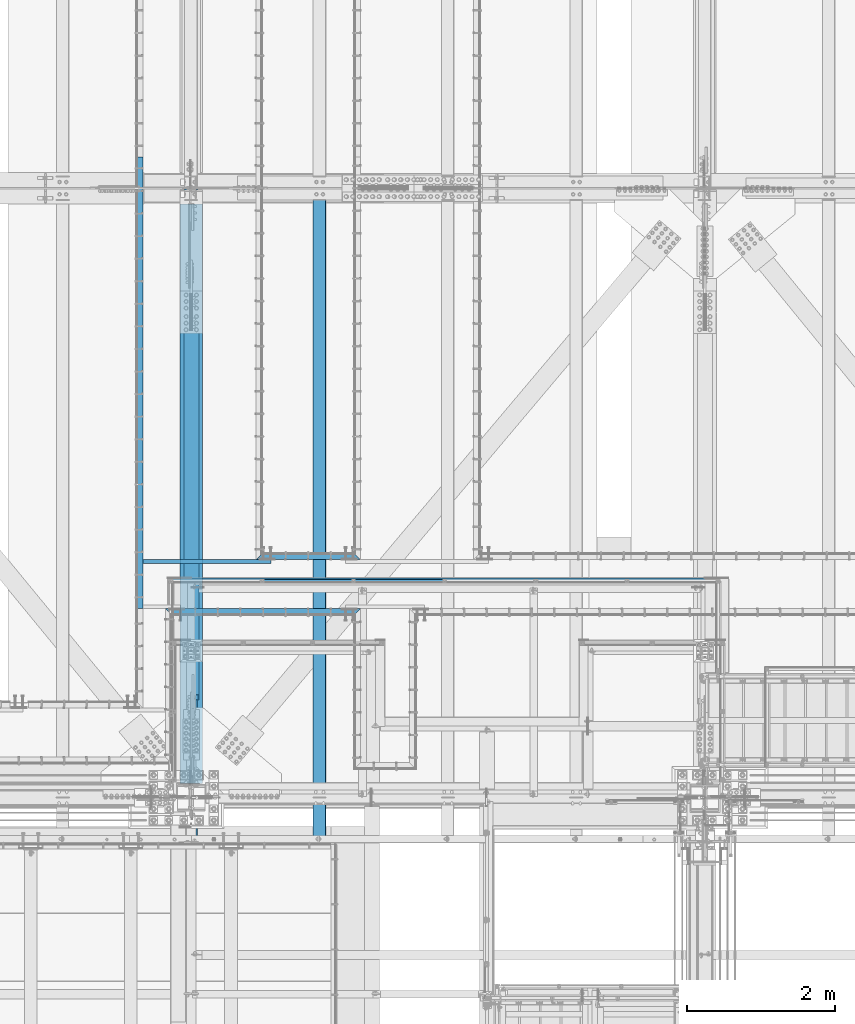
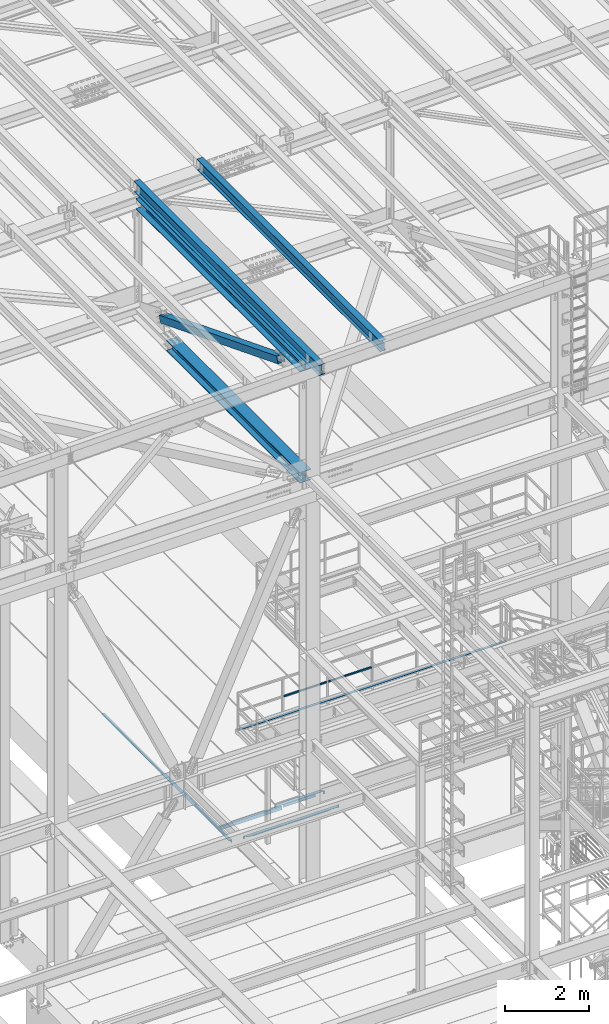
# One storey, part 1783 of 3843: 11 beams, 1 member, 11 elements without a shape of their own.
"""IFC2X3 building model written with IfcOpenShell, lengths in millimetres."""

from ifc_helpers import new_model, si_unit, frame, origin_with_axes, place, context, subcontext, project, spatial, faceted_brep, material, type_object, element, aggregate, save


model = new_model("IFC2X3")

# Units and contexts
model_context = context("Model", 3, precision=1e-05, world=origin_with_axes())
body_context = subcontext(model_context, "Body", "Model", "MODEL_VIEW")
ifc_project = project(units=[si_unit("LENGTHUNIT", "METRE", prefix="MILLI"), si_unit("AREAUNIT", "SQUARE_METRE"), si_unit("VOLUMEUNIT", "CUBIC_METRE"), si_unit("MASSUNIT", "GRAM", prefix="KILO"), si_unit("TIMEUNIT", "SECOND"), si_unit("PLANEANGLEUNIT", "RADIAN"), si_unit("SOLIDANGLEUNIT", "STERADIAN"), si_unit("THERMODYNAMICTEMPERATUREUNIT", "DEGREE_CELSIUS"), si_unit("LUMINOUSINTENSITYUNIT", "LUMEN")], contexts=[model_context])

# Site, building, storey
site_placement = place(None, origin_with_axes())
site = spatial("IfcSite", under=ifc_project, at=site_placement, CompositionType="ELEMENT")
building_placement = place(site_placement, origin_with_axes())
building = spatial("IfcBuilding", under=site, at=building_placement, Name="Undefined", CompositionType="ELEMENT")
storey_placement = place(building_placement, origin_with_axes())
storey = spatial("IfcBuildingStorey", under=building, at=storey_placement, Name="Undefined", CompositionType="ELEMENT", Elevation=0.0)

# Assembly, beam
assembly_1_placement = place(storey_placement, origin_with_axes())
assembly_1 = element("IfcElementAssembly", 1, at=assembly_1_placement, inside=storey, Name="EMBED_ANGLE", AssemblyPlace="NOTDEFINED", PredefinedType="RIGID_FRAME")
ifc_material_1 = material(Name="STEEL/A36")
beam_type_1 = type_object("IfcBeamType", Name="L3-1/2X3-1/2X5/16", PredefinedType="NOTDEFINED")
beam_1_placement = place(assembly_1_placement, frame((49867.3120576172, 28873.45, 30410.15), z_axis=(0.0, 0.0, -1.0), x_axis=(1.0, 0.0, 0.0)))
beam_1 = element("IfcBeam", 2, at=beam_1_placement, type_object=beam_type_1, material=ifc_material_1, Name="EMBED_ANGLE", ObjectType="L3-1/2X3-1/2X5/16", context=body_context, shape_type="Brep", body=[
    faceted_brep([(44.4499023437311, 36.5125000000007, 44.4500000000007), (44.4499023437311, 36.5125000000007, -36.5125000000007), (44.4499023437311, 44.4500000000007, -36.5125000000007), (44.4499023437311, 44.4500000000007, 44.4500000000007), (260.349902343754, 36.5125000000007, -36.5125000000007), (260.349902343754, 44.4500000000007, -36.5125000000044), (260.349902343754, 36.5125000000007, 44.4499999999862), (260.349902343754, 44.4500000000007, 44.4500000000007), (1408.11242675782, 36.5125000000007, 44.4500000000007), (1416.04992675782, 44.4500000000007, 44.4500000000007), (1371.59982910153, 44.4500000000007, 44.4500000000007), (1371.59982910153, 36.5125000000007, 44.4499999999862), (1155.6998291015, 36.5125000000007, -36.5125000000007), (1155.6998291015, 36.5125000000007, 44.4500000000007), (1155.6998291015, 44.4500000000007, -36.5125000000007), (1155.6998291015, 44.4500000000007, 44.4500000000007), (1371.59982910153, 36.5125000000007, -36.5125000000007), (1371.59982910153, 44.4500000000007, -36.5125000000044), (1408.11242675782, 36.5125000000007, -36.5125000000007), (1155.6998291015, -44.4500000000007, -36.5125000000007), (260.349902343754, -44.4500000000007, -36.5125000000007), (88.9000039503298, -44.4500000001644, -36.5125000000007), (88.8999999971129, -44.4500000000007, -44.4499999999971), (1327.14992675782, -44.4500000000007, -44.4500000000007), (1327.14992675782, -44.4500000000007, -36.5125000000007), (44.4499023437311, 0.000101140303740976, -36.5125000000007), (7.93749960740388, 36.5125000000007, -36.5124999999825), (7.93750032749085, 36.5124999999825, 44.4500000000007), (-3.63797880709171e-12, 44.4499999999971, 44.4500000000007), (-3.63797880709171e-12, 44.4499999999971, -44.4500000000007), (1416.04992675782, 44.4500000000007, -44.4500000000007), (1371.59982910153, -9.76562914729584e-05, -36.5125000000007)], [[[0, 1, 2, 3]], [[4, 5, 2, 1]], [[6, 7, 5, 4]], [[8, 9, 10, 11]], [[12, 13, 6, 4]], [[13, 12, 14, 15]], [[16, 17, 14, 12]], [[11, 10, 17, 16]], [[18, 8, 11, 16]], [[19, 20, 21, 22, 23, 24]], [[22, 21, 25, 26, 27, 28, 29]], [[22, 29, 30, 23]], [[8, 18, 31, 24, 23, 30, 9]], [[16, 12, 4, 1, 26, 25, 21, 20, 19, 24, 31, 18]], [[27, 26, 1, 0]], [[28, 27, 0, 3]], [[15, 14, 17, 10, 9, 30, 29, 28, 3, 2, 5, 7]], [[13, 15, 7, 6]]]),
])
aggregate(assembly_1, [beam_1])

assembly_2_placement = place(storey_placement, origin_with_axes())
assembly_2 = element("IfcElementAssembly", 3, at=assembly_2_placement, inside=storey, Name="EMBED_ANGLE", AssemblyPlace="NOTDEFINED", PredefinedType="RIGID_FRAME")
beam_2_placement = place(assembly_2_placement, frame((48648.112, 28124.15, 30410.15), z_axis=(0.0, -1.0, 0.0), x_axis=(1.0, 0.0, 0.0)))
beam_2 = element("IfcBeam", 4, at=beam_2_placement, type_object=beam_type_1, material=ifc_material_1, Name="EMBED_ANGLE", ObjectType="L3-1/2X3-1/2X5/16", context=body_context, shape_type="Brep", body=[
    faceted_brep([(44.4499983150599, -44.4500000000007, -36.5125000001281), (44.4499999898835, -44.4500000000007, -44.4500000001281), (44.4499999898835, 36.5125000000044, -44.4500000001281), (44.4499983150599, 36.5125000000007, -36.5125000001281), (260.349999989907, 36.5125000000044, -44.4500000007247), (260.349998315098, 36.5125000000007, -36.5125000007247), (260.349998315098, -44.4499999999971, -36.5125000007247), (260.349999989907, -44.4500000000007, -44.4500000007247), (2635.24983839615, -44.4500000000007, -44.4500000000007), (2627.31233894619, -44.4500000000007, -36.5125000000007), (2590.79999999994, -44.4500000000007, -36.5125000000007), (2590.79999999994, -44.4500000000007, -44.4500000000007), (2627.31233894619, 36.5125000000007, -36.5125000000007), (2590.79999999994, 36.5125000000007, -36.5125000000007), (2590.79999999994, 36.5125000000007, -44.4500000000007), (2374.89999999993, 36.5125000000007, -36.5125000000007), (2374.89999999993, 36.5125000000007, -44.4500000000007), (2374.89999999993, -44.4500000000007, -36.5125000000007), (2374.89999999993, -44.4500000000007, -44.4500000000007), (3.63797880709171e-12, -44.4499999999971, -44.4500000000007), (-3.63797880709171e-12, 44.4499999999971, -44.4500000000007), (2635.24983839615, 44.4500000000007, -44.4500000000007), (7.93749960740388, -44.4500000000007, -36.5124999999825), (7.93749960740388, 36.5125000000007, -36.5124999999825), (44.4499906109268, 36.5125000000007, -2.28901626542211e-08), (88.8999958229251, 36.5125000000007, 44.4500000001353), (88.8999999965163, 44.4499999999971, 44.4500000000007), (260.349981232008, 36.5125000000007, 44.4499999992695), (2374.89999999993, 36.5125000000007, 44.4500000000007), (2546.34984455661, 36.5125000000007, 44.4500000000007), (2546.34984455661, 44.4500000000007, 44.4500000000007), (2590.79999999994, 36.5125000000007, -0.000158523565914948)], [[[0, 1, 2, 3]], [[3, 2, 4, 5]], [[6, 5, 4, 7]], [[8, 9, 10, 11]], [[9, 12, 13, 10]], [[10, 13, 14, 11]], [[15, 16, 14, 13]], [[17, 18, 16, 15]], [[18, 17, 6, 7]], [[2, 1, 19, 20, 21, 8, 11, 14, 16, 18, 7, 4]], [[22, 19, 1, 0]], [[23, 22, 0, 3]], [[19, 22, 23, 24, 25, 26, 20]], [[26, 25, 27, 28, 29, 30]], [[20, 26, 30, 21]], [[29, 31, 12, 9, 8, 21, 30]], [[28, 27, 25, 24, 23, 3, 5, 15, 13, 12, 31, 29]], [[17, 15, 5, 6]]]),
])
aggregate(assembly_2, [beam_2])

assembly_3_placement = place(storey_placement, origin_with_axes())
assembly_3 = element("IfcElementAssembly", 5, at=assembly_3_placement, inside=storey, Name="EMBED_ANGLE", AssemblyPlace="NOTDEFINED", PredefinedType="RIGID_FRAME")
beam_3_placement = place(assembly_3_placement, frame((48298.8616210938, 28168.6001953125, 30410.15), z_axis=(0.0, 0.0, -1.0), x_axis=(0.0, 1.0, 0.0)))
beam_3 = element("IfcBeam", 6, at=beam_3_placement, type_object=beam_type_1, material=ifc_material_1, Name="EMBED_ANGLE", ObjectType="L3-1/2X3-1/2X5/16", context=body_context, shape_type="Brep", body=[
    faceted_brep([(-3.63797880709171e-12, 44.4499999999971, -44.4500000000007), (-3.63797880709171e-12, 44.4499999999971, 44.4500000000007), (6096.0, 44.4499999999971, 44.4500000000007), (6096.0, 44.4499999999971, -44.4500000000007), (-3.63797880709171e-12, 36.5124999999971, 44.4500000000007), (6096.0, 36.5124999999971, 44.4500000000007), (-3.63797880709171e-12, 36.5124999999971, -36.5125000000007), (6096.0, 36.5124999999971, -36.5125000000007), (3.63797880709171e-12, -44.4499999999971, -36.5125000000007), (6096.0, -44.4499999999971, -36.5125000000007), (3.63797880709171e-12, -44.4499999999971, -44.4500000000007), (6096.0, -44.4499999999971, -44.4500000000007)], [[[0, 1, 2, 3]], [[1, 4, 5, 2]], [[4, 6, 7, 5]], [[6, 8, 9, 7]], [[8, 10, 11, 9]], [[10, 0, 3, 11]], [[5, 7, 9, 11, 3, 2]], [[10, 8, 6, 4, 1, 0]]]),
])
aggregate(assembly_3, [beam_3])

# Assembly, beams
assembly_4_placement = place(storey_placement, origin_with_axes())
assembly_4 = element("IfcElementAssembly", 7, at=assembly_4_placement, inside=storey, Name="RAIL", AssemblyPlace="NOTDEFINED", PredefinedType="RIGID_FRAME")
ifc_material_2 = material()
beam_type_2 = type_object("IfcBeamType", Name="HSS1-1/2X1-1/2X1/4", PredefinedType="NOTDEFINED")
beam_4_placement = place(assembly_4_placement, frame((51185.233333299, 28543.2500000001, 33832.8000002631), z_axis=(0.0, 0.0, 1.0), x_axis=(-1.0, 0.0, 0.0)))
beam_4 = element("IfcBeam", 8, at=beam_4_placement, type_object=beam_type_2, material=ifc_material_2, Name="RAIL", ObjectType="HSS1-1/2X1-1/2X1/4", context=body_context, shape_type="Brep", body=[
    faceted_brep([(1211.79166666124, -19.0499999996136, 19.0499992350015), (1211.79166666124, -19.0499992350015, -19.0499992350015), (1211.79166666124, 19.0499992350015, -19.0499992350015), (1211.79166666124, 19.0499992350015, 19.0499992350015), (1211.79166666124, -12.6999993300014, 12.6999993299978), (1211.79166666124, 12.6999993300014, 12.6999993299978), (1211.79166666124, 12.6999993300014, -12.6999993299978), (1211.79166666124, -12.6999993300014, -12.6999993299978), (19.0499992350015, 19.0499992350015, -19.0499992350015), (19.0499992350015, 19.0499992350015, 19.0499992350015), (19.0499992350015, -19.0499992350015, 19.0499992350015), (19.0499992350015, -19.0499992350015, -19.0499992350015), (19.0499992350015, 12.6999993299978, 12.6999993299978), (19.0499992350015, -12.6999993299978, 12.6999993299978), (19.0499992350015, -12.6999993299978, -12.6999993299978), (19.0499992350015, 12.6999993299978, -12.6999993299978)], [[[0, 1, 2, 3], [4, 5, 6, 7]], [[8, 9, 3, 2]], [[9, 10, 0, 3]], [[10, 11, 1, 0]], [[11, 8, 2, 1]], [[11, 10, 9, 8], [12, 13, 14, 15]], [[14, 13, 4, 7]], [[15, 14, 7, 6]], [[12, 15, 6, 5]], [[13, 12, 5, 4]]]),
])
beam_5_placement = place(assembly_4_placement, frame((52416.0749999603, 28543.2500000003, 33832.8000002631), z_axis=(0.0, 0.0, 1.0), x_axis=(-1.0, 0.0, 0.0)))
beam_5 = element("IfcBeam", 9, at=beam_5_placement, type_object=beam_type_2, material=ifc_material_2, Name="RAIL", ObjectType="HSS1-1/2X1-1/2X1/4", context=body_context, shape_type="Brep", body=[
    faceted_brep([(1211.79166666124, -19.0499999996136, 19.0499992350015), (1211.79166666124, -19.0499992350015, -19.0499992350015), (1211.79166666124, 19.0499992350015, -19.0499992350015), (1211.79166666124, 19.0499992350015, 19.0499992350015), (1211.79166666124, -12.6999993300014, 12.6999993299978), (1211.79166666124, 12.6999993300014, 12.6999993299978), (1211.79166666124, 12.6999993300014, -12.6999993299978), (1211.79166666124, -12.6999993300014, -12.6999993299978), (19.0499992350015, 19.0499992350015, -19.0499992350015), (19.0499992350015, 19.0499992350015, 19.0499992350015), (19.0499992350015, -19.0499992350015, 19.0499992350015), (19.0499992350015, -19.0499992350015, -19.0499992350015), (19.0499992350015, 12.6999993299978, 12.6999993299978), (19.0499992350015, -12.6999993299978, 12.6999993299978), (19.0499992350015, -12.6999993299978, -12.6999993299978), (19.0499992350015, 12.6999993299978, -12.6999993299978)], [[[0, 1, 2, 3], [4, 5, 6, 7]], [[8, 9, 3, 2]], [[9, 10, 0, 3]], [[10, 11, 1, 0]], [[11, 8, 2, 1]], [[11, 10, 9, 8], [12, 13, 14, 15]], [[14, 13, 4, 7]], [[15, 14, 7, 6]], [[12, 15, 6, 5]], [[13, 12, 5, 4]]]),
])
aggregate(assembly_4, [beam_4, beam_5])

# Assembly, beam
assembly_5_placement = place(storey_placement, origin_with_axes())
assembly_5 = element("IfcElementAssembly", 10, at=assembly_5_placement, inside=storey, Name="ref.", AssemblyPlace="NOTDEFINED", PredefinedType="RIGID_FRAME")
ifc_material_3 = material(Name="STEEL/Steel_Undefined")
beam_type_3 = type_object("IfcBeamType", PredefinedType="NOTDEFINED")
beam_6_placement = place(assembly_5_placement, frame((48723.549999976, 28543.25, 33296.2250002631), z_axis=(0.0, 1.0, 0.0), x_axis=(1.0, 0.0, 0.0)))
beam_6 = element("IfcBeam", 11, at=beam_6_placement, type_object=beam_type_3, material=ifc_material_3, Name="ref.", context=body_context, shape_type="Brep", body=[
    faceted_brep([(0.0, 3.17500000000291, -38.0999999999985), (0.0, 3.17500000000291, 38.0999999999985), (7385.04999996748, 3.17500000000291, 38.0999999999985), (7385.04999996748, 3.17500000000291, -38.0999999999985), (0.0, -3.17500000000291, 38.0999999999985), (7385.04999996748, -3.17500000000291, 38.0999999999985), (0.0, -3.17500000000291, -38.0999999999985), (7385.04999996748, -3.17500000000291, -38.0999999999985)], [[[0, 1, 2, 3]], [[1, 4, 5, 2]], [[4, 6, 7, 5]], [[6, 0, 3, 7]], [[5, 7, 3, 2]], [[6, 4, 1, 0]]]),
])
aggregate(assembly_5, [beam_6])

assembly_6_placement = place(storey_placement, origin_with_axes())
assembly_6 = element("IfcElementAssembly", 12, at=assembly_6_placement, inside=storey, Name="BEAM", AssemblyPlace="NOTDEFINED", PredefinedType="RIGID_FRAME")
ifc_material_4 = material(Name="STEEL/A992")
beam_type_4 = type_object("IfcBeamType", Name="W12X26", PredefinedType="NOTDEFINED")
beam_7_placement = place(assembly_6_placement, frame((48993.3092622713, 25006.1945481043, 45836.6957003674), z_axis=(-0.0211520978689295, -0.000677819999713391, 0.99977603957876), x_axis=(0.0, 0.999999770176957, 0.000677972000120135)))
beam_7 = element("IfcBeam", 13, at=beam_7_placement, type_object=beam_type_4, material=ifc_material_4, Name="BEAM", ObjectType="W12X26", context=body_context, shape_type="Brep", body=[
    faceted_brep([(0.0, 82.5500000000029, -155.574999999997), (0.0, 82.5500000000029, -146.050000000003), (8826.50730098035, 82.5499999996973, -146.050000012183), (8826.50084474035, 82.5499999996755, -155.575000012199), (0.0, 3.17500000000291, -146.050000000003), (8826.50843926016, 3.17499999985012, -146.050000011885), (0.0, 3.17500000000291, 146.050000000003), (8826.7064306199, 3.17500000062864, 146.049999988762), (0.0, 82.5500000000029, 146.050000000003), (8826.70529234008, 82.5500000004831, 146.049999988471), (0.0, 82.5500000000029, 155.574999999997), (8826.71174858007, 82.5500000005122, 155.574999988494), (0.0, -82.5500000000029, 155.574999999997), (8826.7141162021, -82.5499999991807, 155.574999989098), (0.0, -82.5500000000029, 146.050000000003), (8826.7076599621, -82.5499999992026, 146.049999989082), (0.0, -3.17500000000291, 146.050000000003), (8826.70652168229, -3.17499999934807, 146.049999988791), (0.0, -3.17500000000291, -146.050000000003), (8826.50853032255, -3.17500000013388, -146.050000011863), (0.0, -82.5500000000029, -146.050000000003), (8826.50966860237, -82.5499999999811, -146.050000011572), (0.0, -82.5500000000029, -155.574999999997), (8826.50321236238, -82.5500000000102, -155.575000011595)], [[[0, 1, 2, 3]], [[1, 4, 5, 2]], [[4, 6, 7, 5]], [[6, 8, 9, 7]], [[8, 10, 11, 9]], [[10, 12, 13, 11]], [[12, 14, 15, 13]], [[14, 16, 17, 15]], [[16, 18, 19, 17]], [[18, 20, 21, 19]], [[20, 22, 23, 21]], [[22, 0, 3, 23]], [[5, 7, 9, 11, 13, 15, 17, 19, 21, 23, 3, 2]], [[22, 20, 18, 16, 14, 12, 10, 8, 6, 4, 1, 0]]]),
])
aggregate(assembly_6, [beam_7])

assembly_7_placement = place(storey_placement, origin_with_axes())
assembly_7 = element("IfcElementAssembly", 14, at=assembly_7_placement, inside=storey, Name="BEAM", AssemblyPlace="NOTDEFINED", PredefinedType="RIGID_FRAME")
beam_8_placement = place(assembly_7_placement, frame((50726.8592622739, 25006.1798301354, 45873.3721148362), z_axis=(-0.0211520983200535, -0.000772423999962485, 0.999775970954405), x_axis=(0.0, 0.999999701546894, 0.000772596999649616)))
beam_8 = element("IfcBeam", 15, at=beam_8_placement, type_object=beam_type_4, material=ifc_material_4, Name="BEAM", ObjectType="W12X26", context=body_context, shape_type="Brep", body=[
    faceted_brep([(20.6571776792152, -3.17500000023574, -130.175000000236), (20.6570739071867, 3.17499999975553, -130.17500000025), (77.7861573661685, 3.17499999975553, -130.175000001203), (77.7861573661612, -3.17500000022847, -130.175000001225), (82.6462368842367, 3.17499999974825, -131.141729923787), (82.6462368842294, -3.17500000022847, -131.141729923816), (86.7664133524158, 3.17499999974098, -133.894743824261), (86.7664133524086, -3.17500000024302, -133.89474382429), (89.5194272529188, 3.17499999974098, -138.014920292408), (89.5194272529079, -3.17500000025029, -138.014920292422), (90.4861571755173, -3.17500000026484, -142.874999810447), (90.4861571755246, 3.17499999972642, -142.874999810425), (90.4861571756519, 3.17499999972642, -146.049999999705), (90.4861571756519, 82.5499999995736, -146.049999999646), (90.4861571756337, 82.5499999995591, -155.574999999626), (90.4861571756337, -82.5500000001412, -155.574999999735), (90.4861571756555, -82.5500000001193, -146.04999999977), (90.4861571756555, -3.17500000026484, -146.049999999705), (8826.7369658244, -82.5499999994499, 146.049999993957), (8826.74432316656, -82.5499999994208, 155.574999993936), (90.4861571743531, -82.5499999995227, 155.516140763844), (90.4861571743641, -82.5499999995664, 146.049999999523), (8826.74162509385, 82.5500000002721, 155.574999994053), (90.4861571743459, 82.5500000001557, 155.574999999619), (8826.73426775169, 82.550000000243, 146.049999994073), (90.4861571743604, 82.5500000001266, 146.049999999639), (8826.73556490204, 3.17500000040309, 146.049999994015), (90.4861571743641, 3.17500000028667, 146.049999999588), (77.786157365128, -3.1749999997337, 130.17499999662), (77.7861573651353, 3.17500000025029, 130.174999996641), (20.8581745930096, 3.17500000025029, 130.17499999694), (20.8582783650381, -3.1749999997337, 130.174999996947), (82.6462368831781, -3.1749999997337, 131.141729919196), (82.646236883189, 3.17500000025757, 131.141729919218), (86.7664133513281, -3.1749999997337, 133.894743819648), (86.7664133513354, 3.17500000025757, 133.894743819677), (89.5194272517874, -3.17499999972642, 138.014920287773), (89.5194272517947, 3.17500000026484, 138.014920287795), (90.4861571743459, -3.17499999971187, 142.87499980579), (90.4861571743568, 3.17500000027212, 142.874999805805), (90.4861571743604, -3.1749999997046, 146.049999999574), (8826.73566867406, -3.17499999958818, 146.049999994015), (8826.50993974233, 3.17499999983556, -146.050000005256), (8826.51004351435, -3.17500000014843, -146.050000005271), (8826.5113406647, -82.5500000000029, -146.050000005322), (8826.50398332253, -82.5500000000247, -155.575000005301), (8826.50128524981, 82.5499999996755, -155.575000005185), (8826.50864259198, 82.54999999969, -146.050000005205), (20.6702627304585, 3.17499999978463, -113.100418057315), (20.8483837380154, 3.17500000022119, 117.499513153998)], [[[0, 1, 2, 3]], [[3, 2, 4, 5]], [[5, 4, 6, 7]], [[7, 6, 8, 9]], [[10, 11, 12, 13, 14, 15, 16, 17]], [[9, 8, 11, 10]], [[18, 19, 20, 21]], [[19, 22, 23, 20]], [[22, 24, 25, 23]], [[24, 26, 27, 25]], [[28, 29, 30, 31]], [[32, 33, 29, 28]], [[34, 35, 33, 32]], [[36, 37, 35, 34]], [[38, 39, 37, 36]], [[20, 23, 25, 27, 39, 38, 40, 21]], [[41, 18, 21, 40]], [[42, 26, 24, 22, 19, 18, 41, 43, 44, 45, 46, 47]], [[44, 43, 17, 16]], [[45, 44, 16, 15]], [[46, 45, 15, 14]], [[47, 46, 14, 13]], [[42, 47, 13, 12]], [[6, 4, 2, 1, 48, 49, 30, 29, 33, 35, 37, 39, 27, 26, 42, 12, 11, 8]], [[31, 30, 49, 48, 1, 0]], [[43, 41, 40, 38, 36, 34, 32, 28, 31, 0, 3, 5, 7, 9, 10, 17]]]),
])
aggregate(assembly_7, [beam_8])

assembly_8_placement = place(storey_placement, origin_with_axes())
assembly_8 = element("IfcElementAssembly", 16, at=assembly_8_placement, inside=storey, Name="BEAM", AssemblyPlace="NOTDEFINED", PredefinedType="RIGID_FRAME")
beam_type_5 = type_object("IfcBeamType", Name="W12X79", PredefinedType="NOTDEFINED")
beam_9_placement = place(assembly_8_placement, frame((48996.6000000252, 25615.8999999988, 42246.55), z_axis=(0.0, -0.000728692999644406, 0.999999734503221), x_axis=(0.0, 0.999999734503221, 0.000728692999635592)))
beam_9 = element("IfcBeam", 17, at=beam_9_placement, type_object=beam_type_5, material=ifc_material_4, Name="BEAM", ObjectType="W12X79", context=body_context, shape_type="Brep", body=[
    faceted_brep([(190.399408939287, -153.987500000003, -138.112499999974), (190.38552733403, -153.987500000003, -157.162499999919), (6546.85173984536, -153.987500000003, -157.162500012535), (6546.85173984529, -153.987500000003, -138.112500012583), (190.399408939287, -6.34999999999854, -138.112499999974), (6546.85173984529, -6.34999999999854, -138.112500012583), (190.600692215554, -6.34999999999854, 138.112499999224), (6546.85173984428, -6.34999999999854, 138.112499986608), (190.600692215554, -153.987500000003, 138.112499999224), (6546.85173984428, -153.987500000003, 138.112499986608), (190.614573820811, -153.987500000003, 157.162499999169), (6546.85173984421, -153.987500000003, 157.162499986553), (190.614573820811, 153.987500000003, 157.162499999169), (6546.85173984421, 153.987500000003, 157.162499986553), (190.600692215554, 153.987500000003, 138.112499999224), (6546.85173984428, 153.987500000003, 138.112499986608), (190.600692215554, 6.34999999999854, 138.112499999224), (6546.85173984428, 6.34999999999854, 138.112499986608), (190.399408939287, 6.34999999999854, -138.112499999974), (6546.85173984529, 6.34999999999854, -138.112500012583), (190.399408939287, 153.987500000003, -138.112499999974), (6546.85173984529, 153.987500000003, -138.112500012583), (190.38552733403, 153.987500000003, -157.162499999919), (6546.85173984536, 153.987500000003, -157.162500012535)], [[[0, 1, 2, 3]], [[4, 0, 3, 5]], [[6, 4, 5, 7]], [[8, 6, 7, 9]], [[10, 8, 9, 11]], [[12, 10, 11, 13]], [[14, 12, 13, 15]], [[16, 14, 15, 17]], [[18, 16, 17, 19]], [[20, 18, 19, 21]], [[1, 0, 4, 6, 8, 10, 12, 14, 16, 18, 20, 22]], [[1, 22, 23, 2]], [[19, 17, 15, 13, 11, 9, 7, 5, 3, 2, 23, 21]], [[22, 20, 21, 23]]]),
])
aggregate(assembly_8, [beam_9])

# Assembly, member
assembly_9_placement = place(storey_placement, origin_with_axes())
assembly_9 = element("IfcElementAssembly", 18, at=assembly_9_placement, inside=storey, AssemblyPlace="NOTDEFINED", PredefinedType="RIGID_FRAME")
ifc_material_5 = material()
member_type = type_object("IfcMemberType", Name="HSS8X8X1/2", PredefinedType="NOTDEFINED")
member_placement = place(assembly_9_placement, frame((48996.6, 33845.5, 42252.5468526654), z_axis=(-1.0, 0.0, 0.0), x_axis=(0.0, -0.930572503542789, 0.366107655820123)))
member = element("IfcMember", 19, at=member_placement, type_object=member_type, material=ifc_material_5, ObjectType="HSS8X8X1/2", context=body_context, shape_type="Brep", body=[
    faceted_brep([(1359.55465263379, -101.600000002009, 17.4625000000087), (1359.55465263849, -88.9000000020551, 17.4625000000087), (1611.96715304129, -88.9000000025098, 17.4625000000087), (1611.96715303657, -101.600000002467, 17.4625000000087), (1618.64976233307, -88.9000000025244, 16.1332463655272), (1618.64976232834, -101.600000002471, 16.1332463655272), (1624.31500493818, -88.900000002528, 12.3478522782098), (1624.31500493347, -101.600000002485, 12.3478522782098), (1628.10039902554, -88.9000000025426, 6.68260967317474), (1628.10039902083, -101.600000002489, 6.68260967317474), (1611.96715303657, -101.600000002467, -17.4624999999942), (1611.96715304129, -88.9000000025098, -17.4624999999942), (1359.55465263849, -88.9000000020551, -17.4624999999942), (1359.55465263379, -101.600000002009, -17.4624999999942), (1618.64976232834, -101.600000002471, -16.1332463655126), (1618.64976233307, -88.9000000025244, -16.1332463655126), (1624.31500493347, -101.600000002485, -12.3478522781952), (1624.31500493818, -88.900000002528, -12.3478522781952), (1628.10039902083, -101.600000002489, -6.68260967316019), (1628.10039902554, -88.9000000025426, -6.68260967316019), (1629.42965265534, -101.600000002492, 3.81478457711637e-07), (1629.42965266005, -88.9000000025462, 3.81478457711637e-07), (1359.5546527043, 88.8999999972311, 17.4625000000087), (1359.55465270902, 101.599999997174, 17.4625000000087), (1611.96715311217, 101.599999996726, 17.4625000000087), (1611.96715310744, 88.8999999967873, 17.4625000000087), (1618.64976240395, 101.599999996715, 16.1332463655272), (1618.64976239922, 88.8999999967727, 16.1332463655272), (1624.31500500906, 101.599999996708, 12.3478522782098), (1624.31500500432, 88.8999999967546, 12.3478522782098), (1628.10039909642, 101.599999996704, 6.68260967317474), (1628.10039909171, 88.8999999967546, 6.68260967317474), (1611.96715310744, 88.8999999967873, -17.4624999999942), (1611.96715311217, 101.599999996726, -17.4624999999942), (1359.55465270902, 101.599999997174, -17.4624999999942), (1359.5546527043, 88.8999999972311, -17.4624999999942), (1618.64976239922, 88.8999999967727, -16.1332463655126), (1618.64976240395, 101.599999996715, -16.1332463655126), (1624.31500500432, 88.8999999967546, -12.3478522781952), (1624.31500500906, 101.599999996708, -12.3478522781952), (1628.10039909171, 88.8999999967546, -6.68260967316019), (1628.10039909642, 101.599999996704, -6.68260967316019), (1629.4296527262, 88.8999999967436, 3.81478457711637e-07), (1629.42965273093, 101.599999996697, 3.81478457711637e-07), (1359.55465263849, -88.9000000020551, 88.9000000000015), (1359.5546527043, 88.8999999972311, 88.9000000000015), (7385.26482110326, 88.89999998651, 88.9000000000015), (7385.26482103745, -88.9000000127944, 88.9000000000015), (1359.55465270902, 101.599999997174, 101.599999999999), (7385.26482110795, 101.599999986456, 101.599999999999), (7385.26483516744, 101.599999994811, -6.34999999999854), (7132.85233479045, 101.599999995, -6.34999999999854), (7126.16972549875, 101.599999995, -7.67925363448012), (7120.5044828937, 101.599999995007, -11.4646477217975), (7116.71908880638, 101.599999995015, -17.1298903268325), (7115.38983517189, 101.599999995007, -23.8125003814712), (7116.71908880638, 101.599999995015, -30.4951096731675), (7120.5044828937, 101.599999995007, -36.1603522782025), (7126.16972549875, 101.599999995, -39.9457463655199), (7132.85233479045, 101.599999995, -41.2750000000015), (7385.26483516744, 101.599999994811, -41.2750000000015), (7385.26482110795, 101.599999986456, -101.599999999999), (1359.55465270902, 101.599999997174, -101.599999999999), (7385.26483516744, 88.8999999947919, -6.34999999999854), (7132.85233479045, 88.8999999949738, -6.34999999999854), (7126.16972549874, 88.899999994981, -7.67925363448012), (7120.50448289369, 88.899999994981, -11.4646477217975), (7116.71908880637, 88.8999999949883, -17.1298903268325), (7115.38983517188, 88.8999999949883, -23.8125003814712), (7116.71908880637, 88.8999999949883, -30.4951096731675), (7120.50448289369, 88.899999994981, -36.1603522782025), (7126.16972549874, 88.899999994981, -39.9457463655199), (7132.85233479045, 88.8999999949738, -41.2750000000015), (7385.26483516744, 88.8999999947919, -41.2750000000015), (1359.5546527043, 88.8999999972311, -88.9000000000015), (1359.55465263849, -88.9000000020551, -88.9000000000015), (7385.26482103745, -88.9000000127944, -88.9000000000015), (7385.26482110326, 88.89999998651, -88.9000000000015), (7126.1697254986, -101.600000005354, -7.67925363448012), (7126.16972549861, -88.9000000053275, -7.67925363448012), (7132.85233479032, -88.9000000053275, -6.34999999999854), (7132.85233479031, -101.600000005354, -6.34999999999854), (7120.50448289355, -101.600000005354, -11.4646477217975), (7120.50448289356, -88.9000000053275, -11.4646477217975), (7116.71908880623, -101.600000005346, -17.1298903268325), (7116.71908880624, -88.9000000053275, -17.1298903268325), (7115.38983517175, -101.600000005339, -23.8125003814712), (7115.38983517175, -88.9000000053275, -23.8125003814712), (7116.71908880623, -101.600000005346, -30.4951096731675), (7116.71908880624, -88.9000000053275, -30.4951096731675), (7120.50448289355, -101.600000005354, -36.1603522782025), (7120.50448289356, -88.9000000053275, -36.1603522782025), (7126.1697254986, -101.600000005354, -39.9457463655199), (7126.16972549861, -88.9000000053275, -39.9457463655199), (7132.85233479031, -101.600000005354, -41.2750000000015), (7132.85233479032, -88.9000000053275, -41.2750000000015), (7385.26483516744, -101.600000005543, -41.2750000000015), (7385.26483516744, -88.9000000055166, -41.2750000000015), (7385.26482103275, -101.600000012741, -101.599999999999), (1359.55465263379, -101.600000002009, -101.599999999999), (7385.26483516744, -88.9000000055166, -6.34999999999854), (7385.26483516744, -101.600000005543, -6.34999999999854), (7385.26482103275, -101.600000012741, 101.599999999999), (1359.55465263379, -101.600000002009, 101.599999999999)], [[[0, 1, 2, 3]], [[3, 2, 4, 5]], [[5, 4, 6, 7]], [[7, 6, 8, 9]], [[10, 11, 12, 13]], [[14, 15, 11, 10]], [[16, 17, 15, 14]], [[18, 19, 17, 16]], [[20, 21, 19, 18]], [[9, 8, 21, 20]], [[22, 23, 24, 25]], [[25, 24, 26, 27]], [[27, 26, 28, 29]], [[29, 28, 30, 31]], [[32, 33, 34, 35]], [[36, 37, 33, 32]], [[38, 39, 37, 36]], [[40, 41, 39, 38]], [[42, 43, 41, 40]], [[31, 30, 43, 42]], [[44, 45, 46, 47]], [[28, 26, 24, 23, 48, 49, 50, 51, 52, 53, 54, 55, 56, 57, 58, 59, 60, 61, 62, 34, 33, 37, 39, 41, 43, 30]], [[63, 64, 51, 50]], [[65, 52, 51, 64]], [[66, 53, 52, 65]], [[67, 54, 53, 66]], [[68, 55, 54, 67]], [[69, 56, 55, 68]], [[70, 57, 56, 69]], [[71, 58, 57, 70]], [[72, 59, 58, 71]], [[73, 60, 59, 72]], [[74, 75, 76, 77]], [[78, 79, 80, 81]], [[82, 83, 79, 78]], [[84, 85, 83, 82]], [[86, 87, 85, 84]], [[88, 89, 87, 86]], [[90, 91, 89, 88]], [[92, 93, 91, 90]], [[94, 95, 93, 92]], [[96, 97, 95, 94]], [[98, 61, 60, 73, 77, 76, 97, 96]], [[99, 62, 61, 98]], [[75, 74, 35, 34, 62, 99, 13, 12]], [[6, 4, 2, 1, 44, 47, 100, 80, 79, 83, 85, 87, 89, 91, 93, 95, 97, 76, 75, 12, 11, 15, 17, 19, 21, 8]], [[101, 81, 80, 100]], [[47, 46, 63, 50, 49, 102, 101, 100]], [[48, 103, 102, 49]], [[16, 14, 10, 13, 99, 98, 96, 94, 92, 90, 88, 86, 84, 82, 78, 81, 101, 102, 103, 0, 3, 5, 7, 9, 20, 18]], [[103, 48, 23, 22, 45, 44, 1, 0]], [[38, 36, 32, 35, 74, 77, 73, 72, 71, 70, 69, 68, 67, 66, 65, 64, 63, 46, 45, 22, 25, 27, 29, 31, 42, 40]]]),
])
aggregate(assembly_9, [member])

# Assembly, beam
assembly_10_placement = place(storey_placement, origin_with_axes())
assembly_10 = element("IfcElementAssembly", 20, at=assembly_10_placement, inside=storey, Name="BEAM", AssemblyPlace="NOTDEFINED", PredefinedType="RIGID_FRAME")
beam_type_6 = type_object("IfcBeamType", Name="W12X65", PredefinedType="NOTDEFINED")
beam_10_placement = place(assembly_10_placement, frame((48996.6000000014, 25615.8999999994, 45490.2521883348), z_axis=(0.0, 0.0, 1.0), x_axis=(0.0, 1.0, 0.0)))
beam_10 = element("IfcBeam", 21, at=beam_10_placement, type_object=beam_type_6, material=ifc_material_4, Name="BEAM", ObjectType="W12X65", context=body_context, shape_type="Brep", body=[
    faceted_brep([(190.499999998636, -152.399999999994, -138.112500000003), (190.499999998636, -152.399999999994, -153.987500000003), (8016.87499999944, -152.399999999994, -153.987500000003), (8016.87499999944, -152.399999999994, -138.112500000003), (190.499999998636, -4.76249999999709, -138.112500000003), (8016.87499999944, -4.76249999999709, -138.112500000003), (190.499999998636, -4.76249999999709, 138.112500000003), (8016.87499999944, -4.76249999999709, 138.112500000003), (190.499999998636, -152.399999999994, 138.112500000003), (8016.87499999944, -152.399999999994, 138.112500000003), (190.499999998636, -152.399999999994, 153.987500000003), (8016.87499999944, -152.399999999994, 153.987500000003), (190.499999998636, 152.399999999994, 153.987500000003), (8016.87499999944, 152.399999999994, 153.987500000003), (190.499999998636, 152.399999999994, 138.112500000003), (8016.87499999944, 152.399999999994, 138.112500000003), (190.499999998636, 4.76249999999709, 138.112500000003), (8016.87499999944, 4.76249999999709, 138.112500000003), (190.499999998636, 4.76249999999709, -138.112500000003), (8016.87499999944, 4.76249999999709, -138.112500000003), (190.499999998636, 152.399999999994, -138.112500000003), (8016.87499999944, 152.399999999994, -138.112500000003), (190.499999998636, 152.399999999994, -153.987500000003), (8016.87499999944, 152.399999999994, -153.987500000003)], [[[0, 1, 2, 3]], [[4, 0, 3, 5]], [[6, 4, 5, 7]], [[8, 6, 7, 9]], [[10, 8, 9, 11]], [[12, 10, 11, 13]], [[14, 12, 13, 15]], [[16, 14, 15, 17]], [[18, 16, 17, 19]], [[20, 18, 19, 21]], [[1, 0, 4, 6, 8, 10, 12, 14, 16, 18, 20, 22]], [[1, 22, 23, 2]], [[19, 17, 15, 13, 11, 9, 7, 5, 3, 2, 23, 21]], [[22, 20, 21, 23]]]),
])
aggregate(assembly_10, [beam_10])

assembly_11_placement = place(storey_placement, origin_with_axes())
assembly_11 = element("IfcElementAssembly", 22, at=assembly_11_placement, inside=storey, Name="COVER PLATE", AssemblyPlace="NOTDEFINED", PredefinedType="RIGID_FRAME")
beam_type_7 = type_object("IfcBeamType", PredefinedType="NOTDEFINED")
beam_11_placement = place(assembly_11_placement, frame((48343.3119423828, 28803.6, 30403.8), z_axis=(0.0, 0.0, 1.0), x_axis=(1.0, 0.0, 0.0)))
beam_11 = element("IfcBeam", 23, at=beam_11_placement, type_object=beam_type_7, material=ifc_material_1, Name="COVER PLATE", context=body_context, shape_type="Brep", body=[
    faceted_brep([(6.54836185276508e-11, 25.4000000000087, -50.7999999999993), (6.54836185276508e-11, 25.4000000000087, 50.7999999999993), (1727.20032324216, 25.3999999999942, 50.7999999999993), (1727.20032324216, 25.3999999999942, -50.7999999999993), (-2.91038304567337e-11, -25.3999999999942, 50.7999999999993), (1727.20032324216, -25.3999999999942, 50.7999999999993), (-2.91038304567337e-11, -25.3999999999942, -50.7999999999993), (1727.20032324216, -25.3999999999942, -50.7999999999993)], [[[0, 1, 2, 3]], [[1, 4, 5, 2]], [[4, 6, 7, 5]], [[6, 0, 3, 7]], [[5, 7, 3, 2]], [[6, 4, 1, 0]]]),
])
aggregate(assembly_11, [beam_11])

save(model, "model.ifc")
